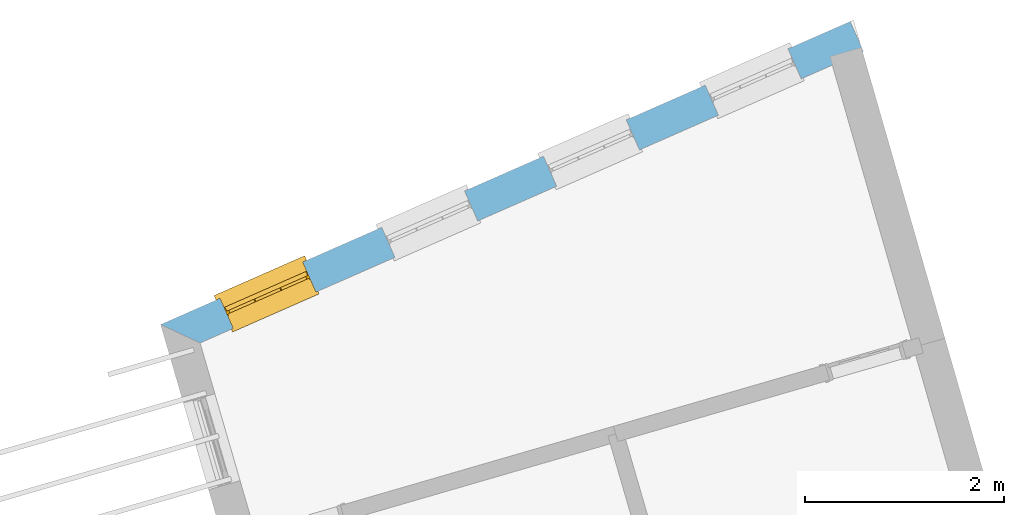
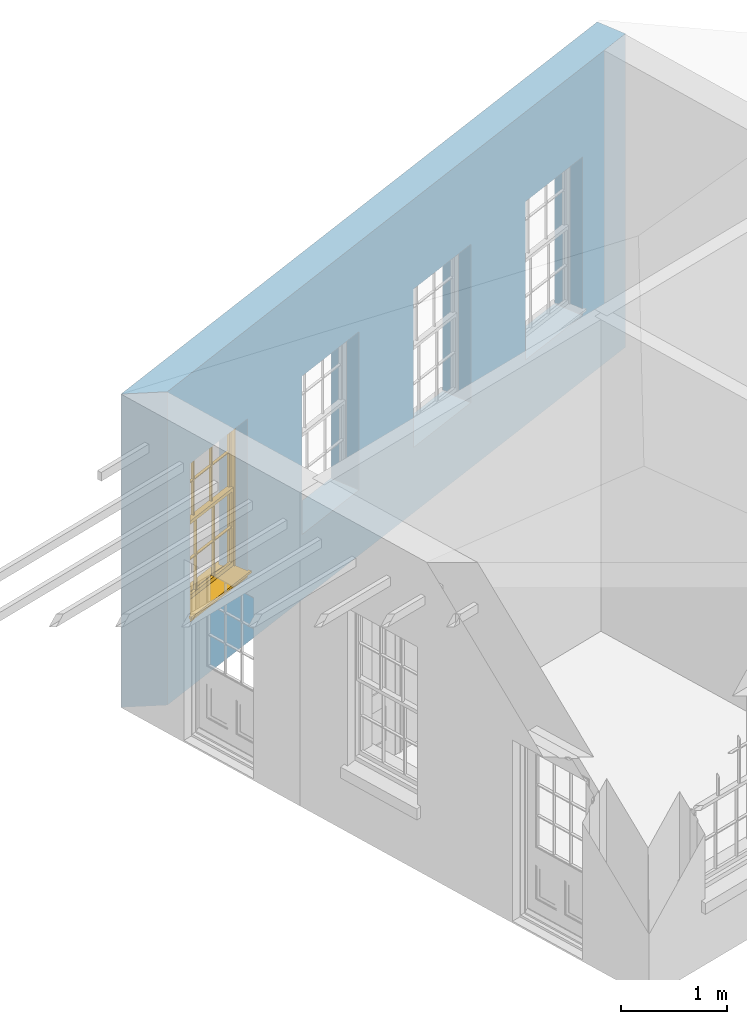
# One storey, part 7 of 10: 1 window, 4 openings, plus 1 element that does not belong to this part.
"""IFC2X3 building model written with IfcOpenShell, lengths in metres."""

from ifc_helpers import new_model, si_unit, frame, origin, place, context, subcontext, project, spatial, polyline, outline, extrude, faceted_brep, material, layer, layer_set, layer_usage, element, fill, save


model = new_model("IFC2X3")

# Units and contexts
model_context = context("Model", 3, world=origin())
body_context = subcontext(model_context, "Body", "Model", "MODEL_VIEW")
ifc_project = project(units=[si_unit("PLANEANGLEUNIT", "RADIAN"), si_unit("MASSUNIT", "GRAM", prefix="KILO"), si_unit("FORCEUNIT", "NEWTON", prefix="KILO"), si_unit("LENGTHUNIT", "METRE")], contexts=[model_context])

# Site, building, storey
site_placement = place(None, origin())
site = spatial("IfcSite", under=ifc_project, at=site_placement, CompositionType="ELEMENT")
building_placement = place(None, origin())
building = spatial("IfcBuilding", under=site, at=building_placement, Name="Building plot-15", CompositionType="ELEMENT")
storey_placement = place(None, frame((0.0, 0.0, 11.05)))
storey = spatial("IfcBuildingStorey", under=building, at=storey_placement, Name="Floor 2", CompositionType="ELEMENT", Elevation=11.05)

# Wall, openings, window
ifc_material = material(Name="Masonry")
ifc_layer = layer(ifc_material, 0.33, ventilated=False)
ifc_layer_set = layer_set([ifc_layer], Name="My Wall")
ifc_layer_usage = layer_usage(ifc_layer_set, "AXIS2", "NEGATIVE", 0.08)
wall_placement = place(storey_placement, origin())
wall = element("IfcWallStandardCase", 1, at=wall_placement, inside=storey, material=ifc_layer_usage, Name="exterior", context=body_context, shape_type="SweptSolid", body=[
    extrude(outline(polyline([(95.6723187451732, 60.4106615143609), (95.5395561949644, 60.7127775603797), (88.6036069877965, 57.6648285454347), (89.0011789339124, 57.4790809319541), (95.6723187451732, 60.4106615143609)])), origin(), (0.0, 0.0, 1.0), 3.6),
])
opening_1_placement = place(storey_placement, frame((0.0, 0.0, 0.75)))
element("IfcOpeningElement", 2, at=opening_1_placement, cuts=wall, Name="Opening", ObjectType="Opening", context=body_context, shape_type="SweptSolid", body=[
    extrude(outline(polyline([(94.9139268152625, 60.4378495880681), (94.0808189307863, 60.0717467980984), (94.2135814809951, 59.7696307520796), (95.0466893654713, 60.1357335420493), (94.9139268152625, 60.4378495880681)])), origin(), (0.0, 0.0, 1.0), 1.82),
])
opening_2_placement = place(storey_placement, frame((0.0, 0.0, 0.75)))
element("IfcOpeningElement", 3, at=opening_2_placement, cuts=wall, Name="Opening", ObjectType="Opening", context=body_context, shape_type="SweptSolid", body=[
    extrude(outline(polyline([(93.2873117562595, 59.7230462325794), (92.4542038717833, 59.3569434426097), (92.5869664219921, 59.0548273965908), (93.4200743064683, 59.4209301865605), (93.2873117562595, 59.7230462325794)])), origin(), (0.0, 0.0, 1.0), 1.82),
])
opening_3_placement = place(storey_placement, frame((0.0, 0.0, 0.75)))
element("IfcOpeningElement", 4, at=opening_3_placement, cuts=wall, Name="Opening", ObjectType="Opening", context=body_context, shape_type="SweptSolid", body=[
    extrude(outline(polyline([(91.6606966972566, 59.0082428770907), (90.8275888127803, 58.642140087121), (90.9603513629891, 58.3400240411021), (91.7934592474653, 58.7061268310718), (91.6606966972566, 59.0082428770907)])), origin(), (0.0, 0.0, 1.0), 1.82),
])
opening_4_placement = place(storey_placement, frame((0.0, 0.0, 0.75)))
opening_4 = element("IfcOpeningElement", 5, at=opening_4_placement, cuts=wall, Name="Opening", ObjectType="Opening", context=body_context, shape_type="SweptSolid", body=[
    extrude(outline(polyline([(90.0340816382536, 58.2934395216019), (89.2009737537774, 57.9273367316322), (89.3337363039862, 57.6252206856134), (90.1668441884623, 57.9913234755831), (90.0340816382536, 58.2934395216019)])), origin(), (0.0, 0.0, 1.0), 1.82),
])
window_placement = place(storey_placement, frame((90.1346593278057, 58.0645637291634, 0.75), z_axis=(0.0, 0.0, 1.0), x_axis=(-0.833107884476192, -0.366102789969688, 0.0)))
window = element("IfcWindow", 6, at=window_placement, inside=storey, Name="circulation outside window", OverallHeight=1.82, OverallWidth=0.91, context=body_context, shape_type="Brep", held_by="IfcProductRepresentation", body=[
    faceted_brep([(0.033125, -0.105, 0.975209), (0.01, -0.105, 0.975209), (0.033125, -0.105, 1.376042), (0.876875, -0.105, 0.975209), (0.876875, -0.105, 1.376042), (0.9, -0.105, 0.975209), (0.876875, -0.105, 1.386042), (0.876875, -0.105, 1.786875), (0.9, -0.105, 1.81), (0.033125, -0.105, 1.786875), (0.033125, -0.105, 1.386042), (0.01, -0.105, 1.81), (0.876875, -0.135, 1.376042), (0.876875, -0.135, 0.975209), (0.9, -0.135, 0.937083), (0.033125, -0.135, 1.786875), (0.01, -0.135, 1.81), (0.033125, -0.135, 1.386042), (0.01, -0.135, 0.937083), (0.033125, -0.135, 0.975209), (0.033125, -0.135, 1.376042), (0.876875, -0.135, 1.786875), (0.876875, -0.135, 1.386042), (0.9, -0.135, 1.81), (0.033125, -0.105, 0.937083), (0.01, -0.105, 0.937083), (0.033125, -0.105, 0.53625), (0.876875, -0.105, 0.937083), (0.876875, -0.105, 0.53625), (0.9, -0.105, 0.937083), (0.876875, -0.105, 0.52625), (0.876875, -0.105, 0.125417), (0.9, -0.105, 0.077167), (0.033125, -0.105, 0.125417), (0.033125, -0.105, 0.52625), (0.01, -0.105, 0.077167), (-0.0425, -0.25, 0.01), (-0.0425, -0.3, 0.001667), (0.0, -0.25, 0.01), (0.9525, -0.25, 0.01), (0.91, -0.25, 0.01), (0.9525, -0.3, 0.001667), (-0.02, 0.08, 0.077167), (0.0, 0.08, 0.077167), (-0.02, 0.11, 0.077167), (0.0, -0.06, 0.077167), (0.01, -0.06, 0.077167), (0.91, -0.06, 0.077167), (0.91, 0.08, 0.077167), (0.9, -0.06, 0.077167), (0.93, 0.08, 0.077167), (0.93, 0.11, 0.077167), (0.01, -0.075, 0.975209), (0.9, -0.075, 0.975209), (0.876875, -0.075, 0.125417), (0.876875, -0.075, 0.52625), (0.9, -0.075, 0.077167), (0.876875, -0.075, 0.53625), (0.876875, -0.075, 0.937083), (0.033125, -0.075, 0.125417), (0.01, -0.075, 0.077167), (0.033125, -0.075, 0.52625), (0.033125, -0.075, 0.937083), (0.033125, -0.075, 0.53625), (-0.02, 0.08, 0.052167), (-0.02, 0.11, 0.052167), (0.93, 0.11, 0.052167), (0.93, 0.08, 0.052167), (0.91, 0.08, 0.052167), (0.0, 0.08, 0.052167), (0.91, -0.15, 0.026667), (0.0, -0.15, 0.026667), (-0.0425, -0.3, -0.123333), (0.9525, -0.3, -0.123333), (-0.0425, -0.25, -0.123333), (0.9525, -0.25, -0.123333), (0.01, -0.06, 1.81), (0.9, -0.06, 1.81), (0.0, -0.06, 1.82), (0.91, -0.06, 1.82), (0.01, -0.15, 0.077167), (0.9, -0.15, 0.077167), (0.592292, -0.105, 0.125417), (0.592292, -0.075, 0.125417), (0.317708, -0.075, 0.125417), (0.317708, -0.105, 0.125417), (0.592292, -0.105, 0.53625), (0.317708, -0.105, 0.53625), (0.317708, -0.105, 0.52625), (0.592292, -0.105, 0.52625), (0.592292, -0.075, 0.53625), (0.317708, -0.075, 0.53625), (0.592292, -0.135, 1.386042), (0.592292, -0.105, 1.386042), (0.317708, -0.105, 1.386042), (0.317708, -0.135, 1.386042), (0.317708, -0.135, 1.376042), (0.592292, -0.135, 1.376042), (0.317708, -0.105, 1.376042), (0.592292, -0.105, 1.376042), (0.602292, -0.135, 1.376042), (0.592292, -0.135, 0.975209), (0.602292, -0.135, 0.975209), (0.602292, -0.105, 0.975209), (0.592292, -0.105, 0.975209), (0.602292, -0.105, 1.376042), (0.602292, -0.075, 0.53625), (0.602292, -0.105, 0.53625), (0.317708, -0.075, 0.52625), (0.307708, -0.075, 0.125417), (0.307708, -0.075, 0.52625), (0.602292, -0.075, 0.52625), (0.602292, -0.075, 0.125417), (0.592292, -0.075, 0.52625), (0.307708, -0.075, 0.53625), (0.317708, -0.075, 0.937083), (0.307708, -0.075, 0.937083), (0.602292, -0.075, 0.937083), (0.592292, -0.075, 0.937083), (0.307708, -0.105, 0.52625), (0.307708, -0.105, 0.125417), (0.307708, -0.105, 0.53625), (0.307708, -0.105, 0.937083), (0.592292, -0.105, 0.937083), (0.317708, -0.105, 0.937083), (0.602292, -0.105, 0.937083), (0.602292, -0.105, 0.52625), (0.602292, -0.105, 0.125417), (0.307708, -0.135, 1.386042), (0.307708, -0.135, 1.376042), (0.307708, -0.135, 0.975209), (0.317708, -0.135, 0.975209), (0.317708, -0.135, 1.786875), (0.307708, -0.135, 1.786875), (0.602292, -0.135, 1.786875), (0.592292, -0.135, 1.786875), (0.602292, -0.135, 1.386042), (0.602292, -0.105, 1.386042), (0.307708, -0.105, 1.386042), (0.307708, -0.105, 1.786875), (0.317708, -0.105, 1.786875), (0.592292, -0.105, 1.786875), (0.602292, -0.105, 1.786875), (0.307708, -0.105, 1.376042), (0.317708, -0.105, 0.975209), (0.307708, -0.105, 0.975209), (0.91, -0.15, 1.82), (0.9, -0.15, 1.81), (0.01, -0.15, 1.81), (0.0, -0.15, 1.82), (0.91, -0.25, 0.0), (0.0, -0.25, 0.0), (0.91, 0.08, 0.0), (0.0, 0.08, 0.0)], [[[0, 1, 2]], [[3, 4, 5]], [[6, 7, 8]], [[9, 10, 11]], [[12, 13, 14]], [[15, 16, 17]], [[18, 19, 20]], [[21, 22, 23]], [[24, 25, 26]], [[27, 28, 29]], [[30, 31, 32]], [[33, 34, 35]], [[14, 27, 29]], [[25, 24, 18]], [[36, 37, 38]], [[39, 40, 41]], [[42, 43, 44]], [[45, 46, 43]], [[47, 48, 49]], [[50, 51, 48]], [[1, 0, 52]], [[5, 53, 3]], [[54, 55, 56]], [[57, 58, 53]], [[59, 60, 61]], [[62, 63, 52]], [[48, 43, 46, 49]], [[51, 44, 43, 48]], [[64, 42, 44, 65]], [[65, 44, 51, 66]], [[66, 51, 50, 67]], [[65, 66, 68, 69]], [[60, 56, 49, 46]], [[70, 71, 38, 40]], [[37, 41, 40, 38]], [[37, 72, 73, 41]], [[74, 75, 73, 72]], [[8, 11, 76, 77]], [[76, 78, 79, 77]], [[32, 35, 80, 81]], [[81, 80, 71, 70]], [[82, 83, 84, 85]], [[86, 87, 88, 89]], [[86, 90, 91, 87]], [[92, 93, 94, 95]], [[92, 95, 96, 97]], [[96, 98, 99, 97]], [[100, 97, 101, 102]], [[103, 104, 99, 105]], [[97, 99, 104, 101]], [[102, 103, 105, 100]], [[28, 57, 106, 107]], [[108, 84, 109, 110]], [[111, 112, 83, 113]], [[114, 110, 61, 63]], [[90, 113, 108, 91]], [[115, 91, 114, 116]], [[117, 106, 90, 118]], [[111, 106, 57, 55]], [[119, 110, 109, 120]], [[34, 61, 110, 119]], [[89, 113, 83, 82]], [[88, 108, 113, 89]], [[85, 84, 108, 88]], [[121, 114, 63, 26]], [[122, 116, 114, 121]], [[123, 118, 90, 86]], [[87, 91, 115, 124]], [[107, 106, 117, 125]], [[126, 111, 55, 30]], [[127, 112, 111, 126]], [[126, 30, 28, 107]], [[88, 119, 120, 85]], [[126, 89, 82, 127]], [[125, 123, 86, 107]], [[121, 26, 34, 119]], [[124, 122, 121, 87]], [[128, 17, 20, 129]], [[96, 129, 130, 131]], [[132, 133, 128, 95]], [[134, 135, 92, 136]], [[100, 12, 22, 136]], [[137, 6, 4, 105]], [[94, 138, 139, 140]], [[137, 93, 141, 142]], [[99, 98, 94, 93]], [[143, 2, 10, 138]], [[144, 145, 143, 98]], [[129, 143, 145, 130]], [[20, 2, 143, 129]], [[131, 144, 98, 96]], [[128, 138, 10, 17]], [[133, 139, 138, 128]], [[135, 141, 93, 92]], [[95, 94, 140, 132]], [[22, 6, 137, 136]], [[136, 137, 142, 134]], [[100, 105, 4, 12]], [[107, 86, 89, 126]], [[106, 111, 113, 90]], [[91, 108, 110, 114]], [[87, 121, 119, 88]], [[97, 100, 136, 92]], [[129, 96, 95, 128]], [[98, 143, 138, 94]], [[105, 99, 93, 137]], [[131, 101, 104, 144]], [[124, 115, 118, 123]], [[132, 140, 141, 135]], [[120, 109, 59, 33]], [[15, 9, 139, 133]], [[134, 142, 7, 21]], [[31, 54, 112, 127]], [[36, 74, 72, 37]], [[39, 41, 73, 75]], [[18, 14, 101, 131]], [[23, 16, 132, 135]], [[83, 56, 60, 84]], [[52, 53, 118, 115]], [[53, 52, 144, 104]], [[11, 8, 141, 140]], [[14, 18, 124, 123]], [[2, 1, 11, 10]], [[8, 5, 4, 6]], [[57, 53, 56, 55]], [[60, 52, 63, 61]], [[26, 25, 35, 34]], [[32, 29, 28, 30]], [[14, 23, 22, 12]], [[18, 20, 17, 16]], [[19, 0, 2, 20]], [[17, 10, 9, 15]], [[12, 4, 3, 13]], [[21, 7, 6, 22]], [[27, 58, 57, 28]], [[30, 55, 54, 31]], [[33, 59, 61, 34]], [[26, 63, 62, 24]], [[5, 8, 77, 53]], [[76, 11, 1, 52]], [[46, 45, 78, 76]], [[49, 77, 79, 47]], [[70, 146, 147, 81]], [[71, 80, 148, 149]], [[19, 130, 145, 0]], [[102, 13, 3, 103]], [[116, 122, 24, 62]], [[29, 32, 81, 14]], [[80, 35, 25, 18]], [[60, 46, 76, 52]], [[77, 49, 56, 53]], [[23, 14, 81, 147]], [[16, 148, 80, 18]], [[35, 85, 120]], [[120, 33, 35]], [[127, 82, 32]], [[32, 31, 127]], [[32, 82, 85, 35]], [[102, 101, 14]], [[14, 13, 102]], [[18, 131, 130]], [[130, 19, 18]], [[134, 21, 23]], [[23, 135, 134]], [[16, 15, 133]], [[133, 132, 16]], [[11, 140, 139]], [[139, 9, 11]], [[142, 141, 8]], [[8, 7, 142]], [[23, 147, 148, 16]], [[146, 149, 148, 147]], [[52, 115, 116]], [[116, 62, 52]], [[118, 53, 117]], [[58, 117, 53]], [[27, 125, 117, 58]], [[56, 83, 112]], [[112, 54, 56]], [[109, 84, 60]], [[60, 59, 109]], [[125, 27, 14]], [[14, 123, 125]], [[122, 124, 18]], [[18, 24, 122]], [[145, 144, 52]], [[52, 0, 145]], [[103, 3, 53]], [[53, 104, 103]], [[79, 78, 149, 146]], [[78, 45, 71, 149]], [[146, 70, 47, 79]], [[150, 75, 74, 151]], [[68, 66, 67]], [[48, 68, 67, 50]], [[69, 64, 65]], [[42, 64, 69, 43]], [[69, 68, 152, 153]], [[70, 68, 48, 47]], [[150, 152, 68, 70]], [[43, 69, 71, 45]], [[69, 153, 151, 71]], [[152, 150, 151, 153]], [[38, 151, 74, 36]], [[71, 151, 38]], [[39, 75, 150, 40]], [[40, 150, 70]]]),
])
fill(opening_4, window)

save(model, "model.ifc")
